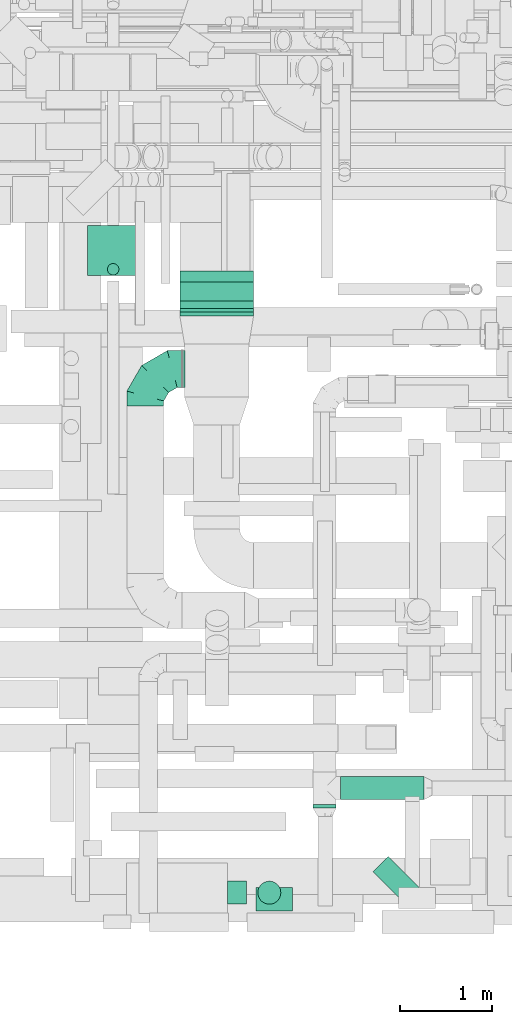
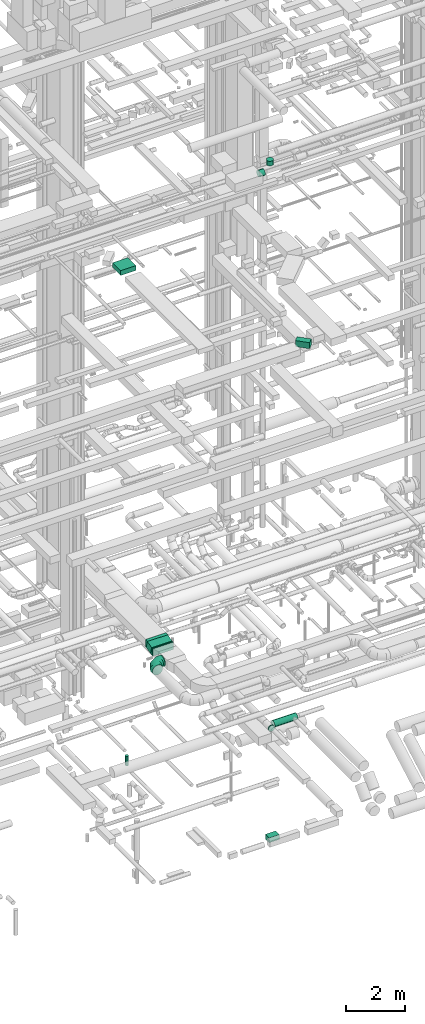
# One storey, part 161 of 337: 10 flow segments, 4 flow fittings.
"""IFC2X3 building model written with IfcOpenShell, lengths in millimetres."""

from ifc_helpers import new_model, entity, si_unit, converted_unit, derived_unit, direction, frame, frame_2d, origin, origin_2d_with_axis, place, context, subcontext, project, spatial, polyline, circle_curve, parameter, trimmed, segment, composite_curve, rectangle, circle, outline, extrude, faceted_brep, source, transform, mapped, material, type_object, type_shapes, element, save


model = new_model("IFC2X3")

# Units and contexts
model_context = context("Model", 3, precision=0.01, world=origin(), true_north=direction((6.12303176911189e-17, 1.0)))
body_context = subcontext(model_context, "Body", "Model", "MODEL_VIEW")
ifc_project = project(units=[si_unit("LENGTHUNIT", "METRE", prefix="MILLI"), si_unit("AREAUNIT", "SQUARE_METRE"), si_unit("VOLUMEUNIT", "CUBIC_METRE"), converted_unit("PLANEANGLEUNIT", "DEGREE", entity("IfcRatioMeasure", 0.0174532925199433), si_unit("PLANEANGLEUNIT", "RADIAN"), dimensions=[0, 0, 0, 0, 0, 0, 0]), si_unit("MASSUNIT", "GRAM", prefix="KILO"), derived_unit("MASSDENSITYUNIT", [(si_unit("MASSUNIT", "GRAM", prefix="KILO"), 1), (si_unit("LENGTHUNIT", "METRE"), -3)]), derived_unit("MOMENTOFINERTIAUNIT", [(si_unit("LENGTHUNIT", "METRE"), 4)]), si_unit("TIMEUNIT", "SECOND"), si_unit("FREQUENCYUNIT", "HERTZ"), si_unit("THERMODYNAMICTEMPERATUREUNIT", "DEGREE_CELSIUS"), derived_unit("THERMALTRANSMITTANCEUNIT", [(si_unit("MASSUNIT", "GRAM", prefix="KILO"), 1), (si_unit("THERMODYNAMICTEMPERATUREUNIT", "KELVIN"), -1), (si_unit("TIMEUNIT", "SECOND"), -3)]), derived_unit("VOLUMETRICFLOWRATEUNIT", [(si_unit("LENGTHUNIT", "METRE"), 3), (si_unit("TIMEUNIT", "SECOND"), -1)]), derived_unit("MASSFLOWRATEUNIT", [(si_unit("MASSUNIT", "GRAM", prefix="KILO"), 1), (si_unit("TIMEUNIT", "SECOND"), -1)]), derived_unit("ROTATIONALFREQUENCYUNIT", [(si_unit("TIMEUNIT", "SECOND"), -1)]), si_unit("ELECTRICCURRENTUNIT", "AMPERE"), si_unit("ELECTRICVOLTAGEUNIT", "VOLT"), si_unit("POWERUNIT", "WATT"), si_unit("FORCEUNIT", "NEWTON", prefix="KILO"), si_unit("ILLUMINANCEUNIT", "LUX"), si_unit("LUMINOUSFLUXUNIT", "LUMEN"), si_unit("LUMINOUSINTENSITYUNIT", "CANDELA"), derived_unit("USERDEFINED", [(si_unit("MASSUNIT", "GRAM", prefix="KILO"), -1), (si_unit("LENGTHUNIT", "METRE"), -2), (si_unit("TIMEUNIT", "SECOND"), 3), (si_unit("LUMINOUSFLUXUNIT", "LUMEN"), 1)]), derived_unit("LINEARVELOCITYUNIT", [(si_unit("LENGTHUNIT", "METRE"), 1), (si_unit("TIMEUNIT", "SECOND"), -1)]), si_unit("PRESSUREUNIT", "PASCAL"), derived_unit("USERDEFINED", [(si_unit("LENGTHUNIT", "METRE"), -2), (si_unit("MASSUNIT", "GRAM", prefix="KILO"), 1), (si_unit("TIMEUNIT", "SECOND"), -2)]), derived_unit("LINEARFORCEUNIT", [(si_unit("MASSUNIT", "GRAM", prefix="KILO"), 1), (si_unit("LENGTHUNIT", "METRE"), 1), (si_unit("TIMEUNIT", "SECOND"), -2), (si_unit("LENGTHUNIT", "METRE"), -1)]), derived_unit("PLANARFORCEUNIT", [(si_unit("MASSUNIT", "GRAM", prefix="KILO"), 1), (si_unit("LENGTHUNIT", "METRE"), 1), (si_unit("TIMEUNIT", "SECOND"), -2), (si_unit("LENGTHUNIT", "METRE"), -2)])], contexts=[model_context])

# Site, building, storey
site_placement = place(None, origin())
site = spatial("IfcSite", under=ifc_project, at=site_placement, CompositionType="ELEMENT")
building_placement = place(site_placement, origin())
building = spatial("IfcBuilding", under=site, at=building_placement, CompositionType="ELEMENT")
storey_placement = place(building_placement, origin())
storey = spatial("IfcBuildingStorey", under=building, at=storey_placement, CompositionType="ELEMENT", Elevation=0.0)

# Flow segments
duct_segment_type_1 = type_object("IfcDuctSegmentType", PredefinedType="NOTDEFINED")
flow_segment_1_placement = place(storey_placement, frame((46600.54, 393.87, -800.0)))
element("IfcFlowSegment", 1, at=flow_segment_1_placement, inside=storey, type_object=duct_segment_type_1, context=body_context, shape_type="SweptSolid", body=[
    extrude(rectangle(XDim=254.999999999911, YDim=399.999999999996, at=origin_2d_with_axis()), frame((200.0, 127.5, 0.0), z_axis=(0.0, 0.0, 1.0), x_axis=(0.0, 1.0, 0.0)), (0.0, 0.0, 1.0), 200.0),
])
flow_segment_2_placement = place(storey_placement, frame((44770.05, 7299.52, 19150.0)))
element("IfcFlowSegment", 2, at=flow_segment_2_placement, inside=storey, type_object=duct_segment_type_1, context=body_context, shape_type="SweptSolid", body=[
    extrude(rectangle(XDim=543.6038969321, YDim=600.000000000002, at=origin_2d_with_axis()), frame((300.0, 271.8, 0.0), z_axis=(0.0, 0.0, 1.0), x_axis=(0.0, -1.0, 0.0)), (0.0, 0.0, 1.0), 200.000000000002),
])
flow_segment_3_placement = place(storey_placement, frame((47873.61, 466.2, 19050.0)))
element("IfcFlowSegment", 3, at=flow_segment_3_placement, inside=storey, type_object=duct_segment_type_1, context=body_context, shape_type="SweptSolid", body=[
    extrude(rectangle(XDim=234.314575050773, YDim=500.000000000003, at=origin_2d_with_axis()), frame((259.62, 259.62, 0.0), z_axis=(0.0, 0.0, 1.0), x_axis=(-0.707106781186507, -0.707106781186588, 0.0)), (0.0, 0.0, 1.0), 249.999999999999),
])
flow_segment_4_placement = place(storey_placement, frame((45775.84, 6939.36, 3315.95)))
element("IfcFlowSegment", 4, at=flow_segment_4_placement, inside=storey, type_object=duct_segment_type_1, context=body_context, shape_type="SweptSolid", body=[
    extrude(rectangle(XDim=300.0, YDim=298.303618249382, at=frame_2d((0.0, 0.0), x_axis=(0.0, 1.0))), frame((0.0, 183.45, 184.05), z_axis=(1.0, 0.0, 0.0), x_axis=(0.0, -0.964545488444064, -0.263916654878395)), (0.0, 0.0, 1.0), 800.000000000009),
])
flow_segment_5_placement = place(storey_placement, frame((45775.84, 6856.24, 3300.0)))
element("IfcFlowSegment", 5, at=flow_segment_5_placement, inside=storey, type_object=duct_segment_type_1, context=body_context, shape_type="SweptSolid", body=[
    extrude(rectangle(XDim=43.5320829059973, YDim=800.0, at=origin_2d_with_axis()), frame((400.0, 21.77, 0.0), z_axis=(0.0, 0.0, 1.0), x_axis=(0.0, 1.0, 0.0)), (0.0, 0.0, 1.0), 300.0),
])
duct_segment_type_2 = type_object("IfcDuctSegmentType", PredefinedType="NOTDEFINED")
flow_segment_6_placement = place(storey_placement, frame((47521.39, 1601.2, 2873.4)))
element("IfcFlowSegment", 6, at=flow_segment_6_placement, inside=storey, type_object=duct_segment_type_2, context=body_context, shape_type="SweptSolid", body=[
    extrude(circle(Radius=125.0, at=origin_2d_with_axis()), frame((0.0, 126.6, 126.6), z_axis=(1.0, 0.0, 0.0), x_axis=(0.0, -1.0, 0.0)), (0.0, 0.0, 1.0), 904.999999999924),
])
flow_segment_7_placement = place(storey_placement, frame((44986.38, 7301.35, -1255.0)))
element("IfcFlowSegment", 7, at=flow_segment_7_placement, inside=storey, type_object=duct_segment_type_2, context=body_context, shape_type="SweptSolid", body=[
    extrude(circle(Radius=62.5, at=origin_2d_with_axis()), frame((64.1, 64.1, 0.0), z_axis=(0.0, 0.0, 1.0), x_axis=(-1.0, 0.0, 0.0)), (0.0, 0.0, 1.0), 389.999999999985),
])
flow_segment_8_placement = place(storey_placement, frame((47219.8, 1512.59, 2873.4)))
element("IfcFlowSegment", 8, at=flow_segment_8_placement, inside=storey, type_object=duct_segment_type_2, context=body_context, shape_type="SweptSolid", body=[
    extrude(circle(Radius=125.0, at=origin_2d_with_axis()), frame((126.6, 0.0, 126.6), z_axis=(0.0, 1.0, 0.0), x_axis=(-1.0, 0.0, 0.0)), (0.0, 0.0, 1.0), 40.1997184),
])
flow_segment_9_placement = place(storey_placement, frame((46294.8, 466.58, 26773.4)))
element("IfcFlowSegment", 9, at=flow_segment_9_placement, inside=storey, type_object=duct_segment_type_2, context=body_context, shape_type="SweptSolid", body=[
    extrude(circle(Radius=125.0, at=origin_2d_with_axis()), frame((0.0, 126.6, 126.6), z_axis=(1.0, 0.0, 0.0), x_axis=(0.0, -1.0, 0.0)), (0.0, 0.0, 1.0), 202.49999999998),
])
flow_segment_10_placement = place(storey_placement, frame((46620.71, 466.58, 27150.0)))
element("IfcFlowSegment", 10, at=flow_segment_10_placement, inside=storey, type_object=duct_segment_type_2, context=body_context, shape_type="SweptSolid", body=[
    extrude(circle(Radius=125.0, at=origin_2d_with_axis()), frame((126.6, 126.6, 0.0), z_axis=(0.0, 0.0, 1.0), x_axis=(0.0, -1.0, 0.0)), (0.0, 0.0, 1.0), 190.000000000017),
])

# Flow fittings
ifc_material = material()
duct_fitting_type_1 = type_object("IfcDuctFittingType", PredefinedType="NOTDEFINED", material=ifc_material)
shared_shape_1 = source(origin(), body_context, "Body", "Brep", [
    faceted_brep([(-400.0, 0.0, -200.0), (-400.0, -44.5, -194.99), (-400.0, -86.78, -180.19), (-400.0, -124.7, -156.37), (-400.0, -156.37, -124.7), (-400.0, -180.19, -86.78), (-400.0, -194.99, -44.5), (-400.0, -200.0, 0.0), (-400.0, -194.99, 44.5), (-400.0, -180.19, 86.78), (-400.0, -156.37, 124.7), (-400.0, -124.7, 156.37), (-400.0, -86.78, 180.19), (-400.0, -44.5, 194.99), (-400.0, 0.0, 200.0), (-400.0, 44.5, 194.99), (-400.0, 86.78, 180.19), (-400.0, 124.7, 156.37), (-400.0, 156.37, 124.7), (-400.0, 180.19, 86.78), (-400.0, 194.99, 44.5), (-400.0, 200.0, 0.0), (-400.0, 194.99, -44.5), (-400.0, 180.19, -86.78), (-400.0, 156.37, -124.7), (-400.0, 124.7, -156.37), (-400.0, 86.78, -180.19), (-400.0, 44.5, -194.99), (-292.82, 0.0, 200.0), (-304.75, 44.5, 194.99), (-316.07, 86.78, 180.19), (-326.23, 124.7, 156.37), (-334.72, 156.37, 124.7), (-341.1, 180.19, 86.78), (-345.07, 194.99, 44.5), (-346.41, 200.0, 0.0), (-345.07, 194.99, -44.5), (-341.1, 180.19, -86.78), (-334.72, 156.37, -124.7), (-326.23, 124.7, -156.37), (-316.07, 86.78, -180.19), (-304.75, 44.5, -194.99), (-292.82, 0.0, -200.0), (-280.9, -44.5, -194.99), (-269.57, -86.78, -180.19), (-259.41, -124.7, -156.37), (-250.92, -156.37, -124.7), (-244.54, -180.19, -86.78), (-240.57, -194.99, -44.5), (-239.23, -200.0, 0.0), (-240.57, -194.99, 44.5), (-244.54, -180.19, 86.78), (-250.92, -156.37, 124.7), (-259.41, -124.7, 156.37), (-269.57, -86.78, 180.19), (-280.9, -44.5, 194.99), (-107.18, 107.18, 200.0), (-139.76, 139.76, 194.99), (-170.7, 170.7, 180.19), (-198.46, 198.46, 156.37), (-221.65, 221.65, 124.7), (-239.09, 239.09, 86.78), (-249.92, 249.92, 44.5), (-253.59, 253.59, 0.0), (-249.92, 249.92, -44.5), (-239.09, 239.09, -86.78), (-221.65, 221.65, -124.7), (-198.46, 198.46, -156.37), (-170.7, 170.7, -180.19), (-139.76, 139.76, -194.99), (-107.18, 107.18, -200.0), (-74.6, 74.6, -194.99), (-43.65, 43.65, -180.19), (-15.89, 15.89, -156.37), (7.29, -7.29, -124.7), (24.73, -24.73, -86.78), (35.56, -35.56, -44.5), (39.23, -39.23, 0.0), (35.56, -35.56, 44.5), (24.73, -24.73, 86.78), (7.29, -7.29, 124.7), (-15.89, 15.89, 156.37), (-43.65, 43.65, 180.19), (-74.6, 74.6, 194.99), (0.0, 292.82, 200.0), (-44.5, 304.75, 194.99), (-86.78, 316.07, 180.19), (-124.7, 326.23, 156.37), (-156.37, 334.72, 124.7), (-180.19, 341.1, 86.78), (-194.99, 345.07, 44.5), (-200.0, 346.41, 0.0), (-194.99, 345.07, -44.5), (-180.19, 341.1, -86.78), (-156.37, 334.72, -124.7), (-124.7, 326.23, -156.37), (-86.78, 316.07, -180.19), (-44.5, 304.75, -194.99), (0.0, 292.82, -200.0), (44.5, 280.9, -194.99), (86.78, 269.57, -180.19), (124.7, 259.41, -156.37), (156.37, 250.92, -124.7), (180.19, 244.54, -86.78), (194.99, 240.57, -44.5), (200.0, 239.23, 0.0), (194.99, 240.57, 44.5), (180.19, 244.54, 86.78), (156.37, 250.92, 124.7), (124.7, 259.41, 156.37), (86.78, 269.57, 180.19), (44.5, 280.9, 194.99), (-44.5, 400.0, -194.99), (-86.78, 400.0, -180.19), (-124.7, 400.0, -156.37), (-156.37, 400.0, -124.7), (-180.19, 400.0, -86.78), (-194.99, 400.0, -44.5), (-200.0, 400.0, 0.0), (-194.99, 400.0, 44.5), (-180.19, 400.0, 86.78), (-156.37, 400.0, 124.7), (-124.7, 400.0, 156.37), (-86.78, 400.0, 180.19), (-44.5, 400.0, 194.99), (0.0, 400.0, 200.0), (44.5, 400.0, 194.99), (86.78, 400.0, 180.19), (124.7, 400.0, 156.37), (156.37, 400.0, 124.7), (180.19, 400.0, 86.78), (194.99, 400.0, 44.5), (200.0, 400.0, 0.0), (194.99, 400.0, -44.5), (180.19, 400.0, -86.78), (156.37, 400.0, -124.7), (124.7, 400.0, -156.37), (86.78, 400.0, -180.19), (44.5, 400.0, -194.99), (0.0, 400.0, -200.0)], [[[0, 1, 2, 3, 4, 5, 6, 7, 8, 9, 10, 11, 12, 13, 14, 15, 16, 17, 18, 19, 20, 21, 22, 23, 24, 25, 26, 27]], [[28, 29, 15, 14]], [[30, 31, 17, 16]], [[29, 30, 16, 15]], [[31, 32, 18, 17]], [[32, 33, 19, 18]], [[34, 35, 21, 20]], [[33, 34, 20, 19]], [[35, 36, 22, 21]], [[37, 38, 24, 23]], [[36, 37, 23, 22]], [[38, 39, 25, 24]], [[39, 40, 26, 25]], [[41, 42, 0, 27]], [[40, 41, 27, 26]], [[1, 0, 42, 43]], [[43, 44, 2, 1]], [[45, 3, 2, 44]], [[45, 46, 4, 3]], [[5, 4, 46, 47]], [[47, 48, 6, 5]], [[49, 7, 6, 48]], [[7, 49, 50, 8]], [[8, 50, 51, 9]], [[9, 51, 52, 10]], [[52, 53, 11, 10]], [[11, 53, 54, 12]], [[12, 54, 55, 13]], [[13, 55, 28, 14]], [[56, 57, 29, 28]], [[58, 59, 31, 30]], [[57, 58, 30, 29]], [[59, 60, 32, 31]], [[60, 61, 33, 32]], [[62, 63, 35, 34]], [[61, 62, 34, 33]], [[63, 64, 36, 35]], [[65, 66, 38, 37]], [[64, 65, 37, 36]], [[66, 67, 39, 38]], [[67, 68, 40, 39]], [[69, 70, 42, 41]], [[68, 69, 41, 40]], [[43, 42, 70, 71]], [[71, 72, 44, 43]], [[73, 45, 44, 72]], [[73, 74, 46, 45]], [[47, 46, 74, 75]], [[75, 76, 48, 47]], [[77, 49, 48, 76]], [[50, 49, 77, 78]], [[51, 50, 78, 79]], [[52, 51, 79, 80]], [[80, 81, 53, 52]], [[54, 53, 81, 82]], [[55, 54, 82, 83]], [[28, 55, 83, 56]], [[84, 85, 57, 56]], [[86, 87, 59, 58]], [[85, 86, 58, 57]], [[87, 88, 60, 59]], [[88, 89, 61, 60]], [[90, 91, 63, 62]], [[89, 90, 62, 61]], [[91, 92, 64, 63]], [[93, 94, 66, 65]], [[92, 93, 65, 64]], [[94, 95, 67, 66]], [[95, 96, 68, 67]], [[97, 98, 70, 69]], [[96, 97, 69, 68]], [[71, 70, 98, 99]], [[99, 100, 72, 71]], [[101, 73, 72, 100]], [[101, 102, 74, 73]], [[75, 74, 102, 103]], [[103, 104, 76, 75]], [[105, 77, 76, 104]], [[78, 77, 105, 106]], [[79, 78, 106, 107]], [[80, 79, 107, 108]], [[108, 109, 81, 80]], [[82, 81, 109, 110]], [[83, 82, 110, 111]], [[56, 83, 111, 84]], [[112, 113, 114, 115, 116, 117, 118, 119, 120, 121, 122, 123, 124, 125, 126, 127, 128, 129, 130, 131, 132, 133, 134, 135, 136, 137, 138, 139]], [[85, 84, 125, 124]], [[86, 85, 124, 123]], [[87, 86, 123, 122]], [[122, 121, 88, 87]], [[89, 88, 121, 120]], [[90, 89, 120, 119]], [[91, 90, 119, 118]], [[91, 118, 117, 92]], [[92, 117, 116, 93]], [[93, 116, 115, 94]], [[115, 114, 95, 94]], [[95, 114, 113, 96]], [[96, 113, 112, 97]], [[97, 112, 139, 98]], [[98, 139, 138, 99]], [[99, 138, 137, 100]], [[100, 137, 136, 101]], [[136, 135, 102, 101]], [[102, 135, 134, 103]], [[103, 134, 133, 104]], [[104, 133, 132, 105]], [[106, 105, 132, 131]], [[107, 106, 131, 130]], [[108, 107, 130, 129]], [[129, 128, 109, 108]], [[110, 109, 128, 127]], [[111, 110, 127, 126]], [[84, 111, 126, 125]]]),
])
type_shapes(duct_fitting_type_1, [shared_shape_1])
flow_fitting_1_placement = place(storey_placement, frame((45399.84, 6281.24, 3450.0), z_axis=(0.0, 0.0, 1.0), x_axis=(-1.0, 0.0, 0.0)))
element("IfcFlowFitting", 11, at=flow_fitting_1_placement, inside=storey, type_object=duct_fitting_type_1, material=ifc_material, context=body_context, shape_type="MappedRepresentation", body=[
    mapped(shared_shape_1, transform((0.0, 0.0, 0.0), scale=1.0)),
])
duct_fitting_type_2 = type_object("IfcDuctFittingType", PredefinedType="NOTDEFINED", material=ifc_material)
shared_shape_2 = source(origin(), body_context, "Body", "Brep", [
    faceted_brep([(20.0, 200.0, 0.0), (20.0, 194.99, 44.5), (20.0, 180.19, 86.78), (20.0, 156.37, 124.7), (20.0, 124.7, 156.37), (20.0, 86.78, 180.19), (20.0, 44.5, 194.99), (20.0, 0.0, 200.0), (20.0, -44.5, 194.99), (20.0, -86.78, 180.19), (20.0, -124.7, 156.37), (20.0, -156.37, 124.7), (20.0, -180.19, 86.78), (20.0, -194.99, 44.5), (20.0, -200.0, 0.0), (20.0, -194.99, -44.5), (20.0, -180.19, -86.78), (20.0, -156.37, -124.7), (20.0, -124.7, -156.37), (20.0, -86.78, -180.19), (20.0, -44.5, -194.99), (20.0, 0.0, -200.0), (20.0, 44.5, -194.99), (20.0, 86.78, -180.19), (20.0, 124.7, -156.37), (20.0, 156.37, -124.7), (20.0, 180.19, -86.78), (20.0, 194.99, -44.5), (0.0, 0.0, 200.0), (0.0, 30.6, 196.55), (-6.1, 22.25, 197.49), (-6.1, 0.0, 200.0), (0.0, 44.5, 194.99), (-6.1, 44.5, 194.99), (0.0, 65.64, 187.59), (0.0, 86.78, 180.19), (-6.1, 65.64, 187.59), (-6.1, 86.78, 180.19), (0.0, 105.74, 168.28), (0.0, 124.7, 156.37), (-6.1, 105.74, 168.28), (-6.1, 124.7, 156.37), (0.0, 140.53, 140.53), (0.0, 156.37, 124.7), (-6.1, 140.53, 140.53), (-6.1, 156.37, 124.7), (0.0, 168.28, 105.74), (0.0, 180.19, 86.78), (-6.1, 168.28, 105.74), (-6.1, 180.19, 86.78), (0.0, 187.59, 65.64), (0.0, 194.99, 44.5), (-6.1, 187.59, 65.64), (-6.1, 194.99, 44.5), (0.0, 197.49, 22.25), (0.0, 200.0, 0.0), (-6.1, 200.0, 0.0), (-6.1, 196.55, 30.6), (0.0, 196.55, -30.6), (-6.1, 197.49, -22.25), (0.0, 194.99, -44.5), (-6.1, 194.99, -44.5), (0.0, 187.59, -65.64), (0.0, 180.19, -86.78), (-6.1, 187.59, -65.64), (-6.1, 180.19, -86.78), (0.0, 168.28, -105.74), (0.0, 156.37, -124.7), (-6.1, 168.28, -105.74), (-6.1, 156.37, -124.7), (0.0, 140.53, -140.53), (0.0, 124.7, -156.37), (-6.1, 140.53, -140.53), (-6.1, 124.7, -156.37), (0.0, 105.74, -168.28), (0.0, 86.78, -180.19), (-6.1, 86.78, -180.19), (-6.1, 105.74, -168.28), (0.0, 44.5, -194.99), (0.0, 65.64, -187.59), (-6.1, 44.5, -194.99), (-6.1, 65.64, -187.59), (0.0, 0.0, -200.0), (0.0, 30.6, -196.55), (-6.1, 22.25, -197.49), (-6.1, 0.0, -200.0), (0.0, -30.6, -196.55), (-6.1, -22.25, -197.49), (0.0, -44.5, -194.99), (-6.1, -44.5, -194.99), (0.0, -65.64, -187.59), (0.0, -86.78, -180.19), (-6.1, -65.64, -187.59), (-6.1, -86.78, -180.19), (0.0, -105.74, -168.28), (0.0, -124.7, -156.37), (-6.1, -105.74, -168.28), (-6.1, -124.7, -156.37), (0.0, -140.53, -140.53), (0.0, -156.37, -124.7), (-6.1, -140.53, -140.53), (-6.1, -156.37, -124.7), (0.0, -168.28, -105.74), (0.0, -180.19, -86.78), (-6.1, -168.28, -105.74), (-6.1, -180.19, -86.78), (0.0, -194.99, -44.5), (0.0, -196.55, -30.6), (0.0, -200.0, 0.0), (-6.1, -197.49, -22.25), (-6.1, -200.0, 0.0), (-6.1, -194.99, -44.5), (0.0, -187.59, -65.64), (-6.1, -187.59, -65.64), (0.0, -196.55, 30.6), (-6.1, -197.49, 22.25), (0.0, -194.99, 44.5), (-6.1, -194.99, 44.5), (0.0, -187.59, 65.64), (0.0, -180.19, 86.78), (-6.1, -187.59, 65.64), (-6.1, -180.19, 86.78), (0.0, -168.28, 105.74), (0.0, -156.37, 124.7), (-6.1, -168.28, 105.74), (-6.1, -156.37, 124.7), (0.0, -140.53, 140.53), (0.0, -124.7, 156.37), (-6.1, -140.53, 140.53), (-6.1, -124.7, 156.37), (0.0, -105.74, 168.28), (0.0, -86.78, 180.19), (-6.1, -105.74, 168.28), (-6.1, -86.78, 180.19), (0.0, -65.64, 187.59), (0.0, -44.5, 194.99), (-6.1, -65.64, 187.59), (-6.1, -44.5, 194.99), (0.0, -22.25, 197.49), (-6.1, -30.6, 196.55)], [[[0, 1, 2, 3, 4, 5, 6, 7, 8, 9, 10, 11, 12, 13, 14, 15, 16, 17, 18, 19, 20, 21, 22, 23, 24, 25, 26, 27]], [[28, 7, 6]], [[6, 29, 28]], [[28, 29, 30]], [[31, 28, 30]], [[6, 32, 29]], [[32, 33, 29]], [[29, 33, 30]], [[6, 5, 32]], [[5, 34, 32]], [[5, 35, 34]], [[36, 34, 35]], [[35, 37, 36]], [[33, 34, 36]], [[34, 33, 32]], [[4, 35, 5]], [[4, 38, 35]], [[4, 39, 38]], [[38, 39, 40]], [[39, 41, 40]], [[37, 38, 40]], [[38, 37, 35]], [[4, 3, 39]], [[3, 42, 39]], [[3, 43, 42]], [[44, 42, 43]], [[43, 45, 44]], [[41, 42, 44]], [[39, 42, 41]], [[43, 3, 2]], [[2, 46, 43]], [[45, 43, 46]], [[2, 47, 46]], [[47, 48, 46]], [[47, 49, 48]], [[45, 46, 48]], [[2, 1, 47]], [[1, 50, 47]], [[1, 51, 50]], [[52, 50, 51]], [[51, 53, 52]], [[49, 50, 52]], [[50, 49, 47]], [[0, 51, 1]], [[0, 54, 51]], [[0, 55, 54]], [[55, 56, 54]], [[56, 57, 54]], [[57, 51, 54]], [[51, 57, 53]], [[55, 0, 27]], [[27, 58, 55]], [[55, 58, 59]], [[56, 55, 59]], [[27, 60, 58]], [[60, 61, 58]], [[58, 61, 59]], [[27, 26, 60]], [[26, 62, 60]], [[26, 63, 62]], [[64, 62, 63]], [[63, 65, 64]], [[61, 62, 64]], [[62, 61, 60]], [[25, 63, 26]], [[25, 66, 63]], [[25, 67, 66]], [[66, 67, 68]], [[67, 69, 68]], [[65, 66, 68]], [[66, 65, 63]], [[25, 24, 67]], [[24, 70, 67]], [[24, 71, 70]], [[72, 70, 71]], [[71, 73, 72]], [[69, 70, 72]], [[67, 70, 69]], [[24, 23, 71]], [[23, 74, 71]], [[23, 75, 74]], [[74, 75, 76]], [[76, 77, 74]], [[73, 74, 77]], [[73, 71, 74]], [[23, 22, 78]], [[23, 78, 79]], [[23, 79, 75]], [[79, 78, 80]], [[79, 80, 81]], [[81, 75, 79]], [[75, 81, 76]], [[82, 22, 21]], [[22, 82, 83]], [[82, 84, 83]], [[82, 85, 84]], [[80, 83, 84]], [[83, 80, 78]], [[22, 83, 78]], [[82, 21, 20]], [[20, 86, 82]], [[82, 86, 87]], [[85, 82, 87]], [[20, 88, 86]], [[88, 89, 86]], [[86, 89, 87]], [[20, 19, 88]], [[19, 90, 88]], [[19, 91, 90]], [[92, 90, 91]], [[91, 93, 92]], [[89, 90, 92]], [[90, 89, 88]], [[18, 91, 19]], [[18, 94, 91]], [[18, 95, 94]], [[94, 95, 96]], [[95, 97, 96]], [[93, 94, 96]], [[94, 93, 91]], [[18, 17, 95]], [[17, 98, 95]], [[17, 99, 98]], [[100, 98, 99]], [[99, 101, 100]], [[97, 98, 100]], [[95, 98, 97]], [[17, 16, 99]], [[16, 102, 99]], [[16, 103, 102]], [[103, 104, 102]], [[103, 105, 104]], [[101, 102, 104]], [[101, 99, 102]], [[15, 14, 106]], [[14, 107, 106]], [[14, 108, 107]], [[108, 109, 107]], [[108, 110, 109]], [[111, 107, 109]], [[107, 111, 106]], [[16, 15, 106]], [[16, 106, 112]], [[16, 112, 103]], [[112, 106, 111]], [[112, 111, 113]], [[103, 113, 105]], [[113, 103, 112]], [[108, 14, 13]], [[13, 114, 108]], [[108, 114, 115]], [[110, 108, 115]], [[13, 116, 114]], [[116, 117, 114]], [[114, 117, 115]], [[13, 12, 116]], [[12, 118, 116]], [[12, 119, 118]], [[120, 118, 119]], [[119, 121, 120]], [[117, 118, 120]], [[118, 117, 116]], [[11, 119, 12]], [[11, 122, 119]], [[11, 123, 122]], [[122, 123, 124]], [[123, 125, 124]], [[121, 122, 124]], [[122, 121, 119]], [[11, 10, 123]], [[10, 126, 123]], [[10, 127, 126]], [[128, 126, 127]], [[127, 129, 128]], [[125, 126, 128]], [[123, 126, 125]], [[127, 10, 9]], [[9, 130, 127]], [[129, 127, 130]], [[9, 131, 130]], [[131, 132, 130]], [[131, 133, 132]], [[129, 130, 132]], [[9, 8, 131]], [[8, 134, 131]], [[8, 135, 134]], [[136, 134, 135]], [[135, 137, 136]], [[133, 134, 136]], [[134, 133, 131]], [[7, 135, 8]], [[7, 138, 135]], [[7, 28, 138]], [[28, 31, 138]], [[31, 139, 138]], [[139, 135, 138]], [[135, 139, 137]], [[87, 89, 92, 93, 96, 97, 100, 101, 104, 105, 113, 111, 109, 110, 115, 117, 120, 121, 124, 125, 128, 129, 132, 133, 136, 137, 139, 31, 30, 33, 36, 37, 40, 41, 44, 45, 48, 49, 52, 53, 57, 56, 59, 61, 64, 65, 68, 69, 72, 73, 77, 76, 81, 80, 84, 85]]]),
])
type_shapes(duct_fitting_type_2, [shared_shape_2])
flow_fitting_2_placement = place(storey_placement, frame((45825.84, 6281.24, 3450.0), z_axis=(0.0, 0.0, -1.0), x_axis=(-1.0, 0.0, 0.0)))
element("IfcFlowFitting", 12, at=flow_fitting_2_placement, inside=storey, type_object=duct_fitting_type_2, material=ifc_material, context=body_context, shape_type="MappedRepresentation", body=[
    mapped(shared_shape_2, transform((0.0, 0.0, 0.0), scale=1.0)),
])
duct_fitting_type_3 = type_object("IfcDuctFittingType", PredefinedType="NOTDEFINED", material=ifc_material)
shared_shape_3 = source(origin(), body_context, "Body", "SweptSolid", [
    extrude(outline(composite_curve([segment(polyline([(-155.32, -39.59), (144.68, -39.59)]), True, "CONTINUOUS"), segment(trimmed(circle_curve(frame_2d((294.68, -39.59), x_axis=(-0.964545488444079, 0.263916654878339)), 150.0), [parameter(0.0)], [parameter(15.3025901961681)], True, "PARAMETER"), False, "CONTINUOUS"), segment(polyline([(150.0, 0.0), (-139.36, 79.17)]), True, "CONTINUOUS"), segment(trimmed(circle_curve(frame_2d((294.68, -39.59), x_axis=(-0.964545488444079, 0.263916654878339)), 450.0), [parameter(0.0)], [parameter(15.3025901961681)], True, "PARAMETER"), True, "CONTINUOUS")], self_intersect=False)), frame((-0.71, 5.32, -400.0), z_axis=(0.0, 0.0, 1.0), x_axis=(-0.26391665487834, 0.964545488444079, 0.0)), (0.0, 0.0, 1.0), 800.0),
])
type_shapes(duct_fitting_type_3, [shared_shape_3])
for number, where, z_axis, x_axis in (
    (13, (46175.84, 7305.55, 3550.0), (1.0, 0.0, 0.0), (0.0, -1.0, 0.0)),
    (14, (46175.84, 6940.08, 3450.0), (-1.0, 0.0, 0.0), (0.0, -0.964545488444064, -0.263916654878395)),
):
    element("IfcFlowFitting", number, at=place(storey_placement, frame(where, z_axis=z_axis, x_axis=x_axis)), inside=storey, type_object=duct_fitting_type_3, material=ifc_material, context=body_context, shape_type="MappedRepresentation", body=[
        mapped(shared_shape_3, transform((0.0, 0.0, 0.0), scale=1.0)),
    ])

save(model, "model.ifc")
